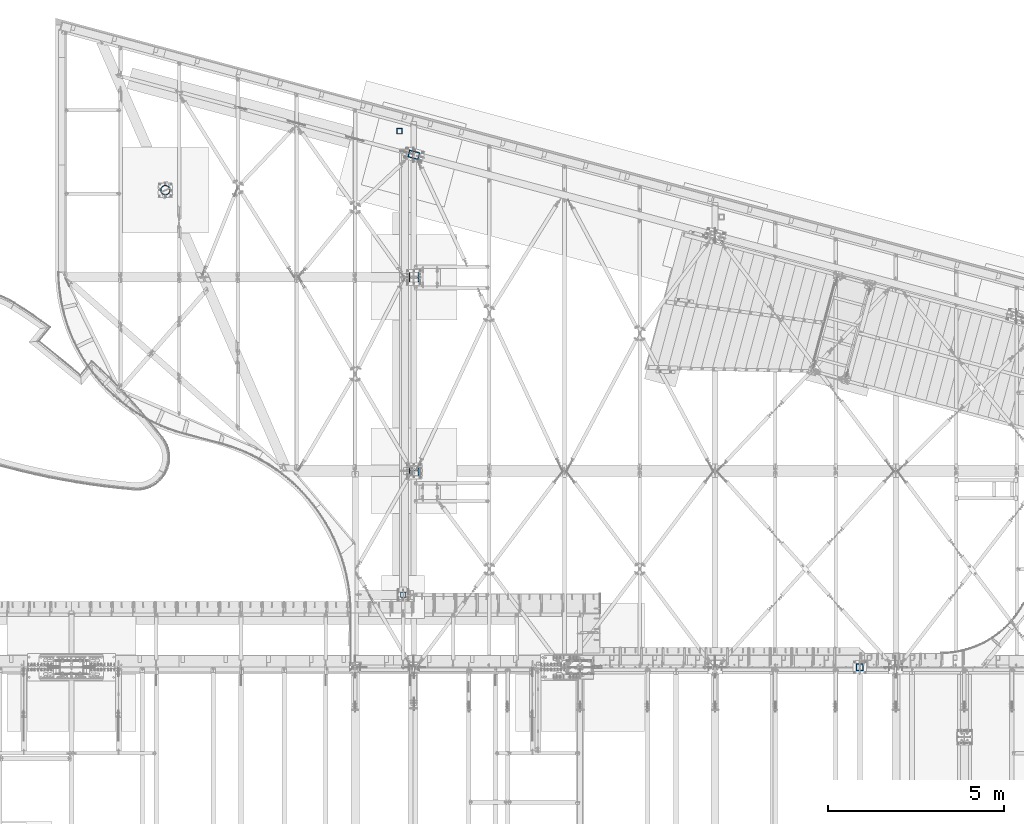
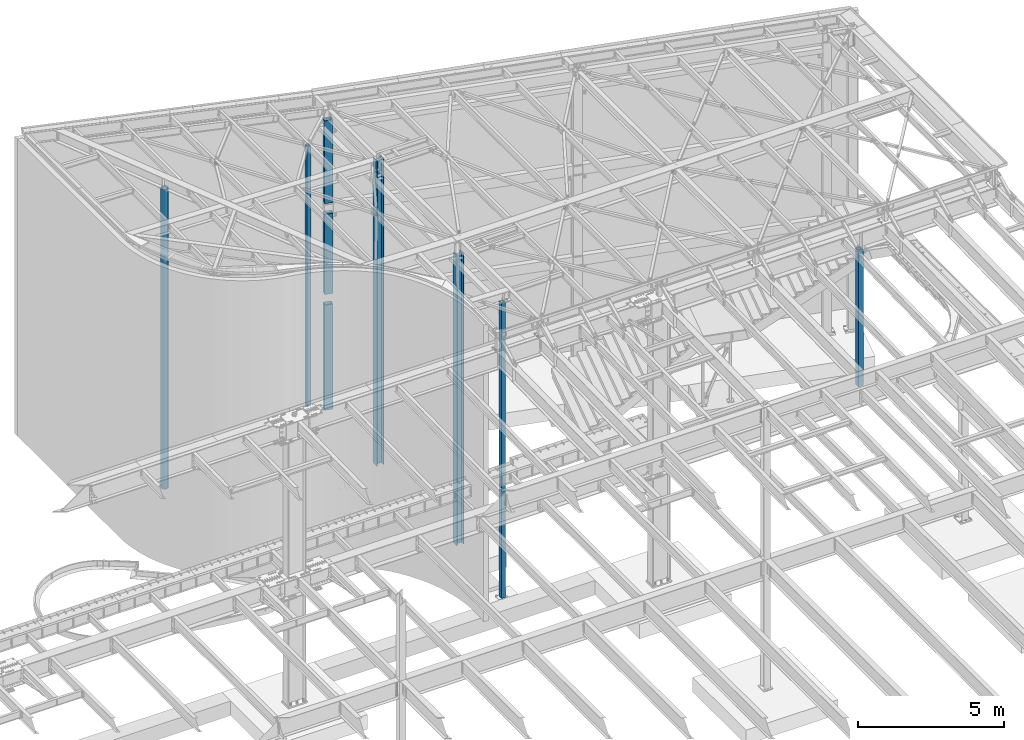
# One storey, part 914 of 1763: 9 columns, 7 elements without a shape of their own.
"""IFC2X3 building model written with IfcOpenShell, lengths in millimetres."""

from ifc_helpers import new_model, si_unit, frame, origin_with_axes, place, context, subcontext, project, spatial, faceted_brep, material, type_object, element, aggregate, save


model = new_model("IFC2X3")

# Units and contexts
model_context = context("Model", 3, precision=1e-05, world=origin_with_axes())
body_context = subcontext(model_context, "Body", "Model", "MODEL_VIEW")
ifc_project = project(units=[si_unit("LENGTHUNIT", "METRE", prefix="MILLI"), si_unit("AREAUNIT", "SQUARE_METRE"), si_unit("VOLUMEUNIT", "CUBIC_METRE"), si_unit("MASSUNIT", "GRAM", prefix="KILO"), si_unit("TIMEUNIT", "SECOND"), si_unit("PLANEANGLEUNIT", "RADIAN"), si_unit("SOLIDANGLEUNIT", "STERADIAN"), si_unit("THERMODYNAMICTEMPERATUREUNIT", "DEGREE_CELSIUS"), si_unit("LUMINOUSINTENSITYUNIT", "LUMEN")], contexts=[model_context])

# Site, building, storey
site_placement = place(None, origin_with_axes())
site = spatial("IfcSite", under=ifc_project, at=site_placement, CompositionType="ELEMENT")
building_placement = place(site_placement, origin_with_axes())
building = spatial("IfcBuilding", under=site, at=building_placement, Name="Undefined", CompositionType="ELEMENT")
storey_placement = place(building_placement, origin_with_axes())
storey = spatial("IfcBuildingStorey", under=building, at=storey_placement, Name="Undefined", CompositionType="ELEMENT", Elevation=0.0)

# Assembly, columns
assembly_1_placement = place(storey_placement, origin_with_axes())
assembly_1 = element("IfcElementAssembly", 1, at=assembly_1_placement, inside=storey, Name="COLUMN", AssemblyPlace="NOTDEFINED", PredefinedType="RIGID_FRAME")
ifc_material_1 = material()
column_type_1 = type_object("IfcColumnType", Name="HSS12X8X5/8", PredefinedType="NOTDEFINED")
column_1_placement = place(assembly_1_placement, frame((-39672.2896174351, 66681.4025701154, 8483.6), z_axis=(-0.965913267114846, 0.258865912030774, 0.0), x_axis=(0.0, 0.0, 1.0)))
column_1 = element("IfcColumn", 2, at=column_1_placement, type_object=column_type_1, material=ifc_material_1, Name="COLUMN", ObjectType="HSS12X8X5/8", context=body_context, shape_type="Brep", body=[
    faceted_brep([(3505.2, 85.725000000275, 136.525000000154), (3505.2, 85.7249999985142, -136.525000000358), (3489.32500001276, 101.599999998311, -152.400000000394), (3489.32499994588, 101.60000000026, 152.400000000154), (3505.2, -85.7250000002605, -136.52500000014), (3489.32500001817, -101.600000000253, -152.40000000014), (3505.1999999888, -85.7250000086715, 136.524999979003), (3489.32499994455, -101.599999998238, 152.400000000431), (22.2250001691827, -101.599999999904, -152.40000000006), (6.35000000000036, -85.7249999999112, -136.525000000045), (6.35000000000036, 85.7250000000859, -136.524999999936), (22.22500016919, 101.600000000093, -152.399999999921), (22.2249997738745, -101.599999773942, 152.400000112088), (6.35000000000036, -85.7250000000786, 136.524999999943), (22.2249996600258, 101.599999999904, 152.40000000006), (6.35000000000036, 85.7249999999112, 136.525000000045)], [[[0, 1, 2, 3]], [[4, 5, 2, 1]], [[6, 7, 5, 4]], [[8, 9, 10, 11]], [[12, 13, 9, 8]], [[14, 15, 13, 12]], [[13, 15, 0, 6]], [[9, 13, 6, 4]], [[10, 9, 4, 1]], [[15, 10, 1, 0]], [[14, 11, 10, 15]], [[11, 14, 3, 2]], [[8, 11, 2, 5]], [[12, 8, 5, 7]], [[14, 12, 7, 3]], [[0, 3, 7, 6]]]),
])
column_2_placement = place(assembly_1_placement, frame((-39672.2896174482, 66681.4025701186, 4673.6), z_axis=(-0.965913267114846, 0.258865912030774, 0.0), x_axis=(0.0, 0.0, 1.0)))
column_2 = element("IfcColumn", 3, at=column_2_placement, type_object=column_type_1, material=ifc_material_1, Name="COLUMN", ObjectType="HSS12X8X5/8", context=body_context, shape_type="Brep", body=[
    faceted_brep([(3397.25, 85.7249999999185, 136.525000000045), (3397.25, 85.7250000000859, -136.524999999936), (3381.37499999995, 101.600000000093, -152.399999999921), (3381.37500000165, 101.599999999904, 152.40000000006), (3397.25, -85.724999999904, -136.525000000045), (3381.37499999999, -101.599999999897, -152.40000000006), (3397.25, -85.7250000001004, 136.524999999914), (3381.37500000178, -101.600000000079, 152.399999999929), (22.2250001691827, -101.599999999904, -152.40000000006), (6.35000000000036, -85.7249999999112, -136.525000000045), (6.35000000000036, 85.7250000000859, -136.524999999936), (22.22500016919, 101.600000000093, -152.399999999921), (22.2249997738745, -101.599999773942, 152.400000112088), (6.35000000000036, -85.7250000000786, 136.524999999943), (22.2249996600258, 101.599999999904, 152.40000000006), (6.35000000000036, 85.7249999999112, 136.525000000045)], [[[0, 1, 2, 3]], [[4, 5, 2, 1]], [[6, 7, 5, 4]], [[8, 9, 10, 11]], [[12, 13, 9, 8]], [[14, 15, 13, 12]], [[13, 15, 0, 6]], [[9, 13, 6, 4]], [[10, 9, 4, 1]], [[15, 10, 1, 0]], [[14, 11, 10, 15]], [[11, 14, 3, 2]], [[8, 11, 2, 5]], [[12, 8, 5, 7]], [[14, 12, 7, 3]], [[0, 3, 7, 6]]]),
])
column_3_placement = place(assembly_1_placement, frame((-39672.2896174145, 66681.4025701092, -304.799999999999), z_axis=(-0.965913267114846, 0.258865912030774, 0.0), x_axis=(0.0, 0.0, 1.0)))
column_3 = element("IfcColumn", 4, at=column_3_placement, type_object=column_type_1, material=ifc_material_1, Name="COLUMN", ObjectType="HSS12X8X5/8", context=body_context, shape_type="Brep", body=[
    faceted_brep([(146.049999998875, 101.599999999904, 152.40000000006), (146.050000000008, 101.6000000001, -152.399999999921), (133.349999999999, 88.9000000001033, -139.69999999991), (133.349999999999, 88.9000000002707, 139.700000000703), (146.050000000045, -101.599999999897, -152.40000000006), (133.349999999999, -88.8999999998487, -139.700000000019), (146.04999999961, -101.599999999642, 152.399999999507), (133.349999999999, -88.9000000004235, 139.700000000703), (133.349999999999, 85.7249999999185, 136.525000000045), (133.349999999999, 85.7250000000931, -136.524999999936), (4565.65, 85.7250000000786, -136.524999999936), (4565.65, 85.7249999999112, 136.525000000045), (133.349999999999, -85.7250000000786, 136.524999999936), (4565.65000001169, -85.724999988437, 136.525000023285), (133.349999999999, -85.724999999904, -136.525000000045), (4565.65, -85.7249999999112, -136.525000000045), (4549.77500003684, -101.600000000093, 152.399999999921), (4549.77499998247, -101.599999999897, -152.40000000006), (4549.77500003671, 101.599999999904, 152.400000000052), (4549.7749999824, 101.600000000093, -152.399999999929)], [[[0, 1, 2, 3]], [[4, 5, 2, 1]], [[6, 7, 5, 4]], [[8, 9, 10, 11]], [[12, 8, 11, 13]], [[14, 12, 13, 15]], [[13, 16, 17, 15]], [[11, 18, 16, 13]], [[16, 18, 0, 6]], [[17, 16, 6, 4]], [[19, 17, 4, 1]], [[18, 19, 1, 0]], [[11, 10, 19, 18]], [[15, 17, 19, 10]], [[9, 14, 15, 10]], [[3, 2, 5, 7], [8, 12, 14, 9]], [[0, 3, 7, 6]]]),
])
aggregate(assembly_1, [column_1, column_2, column_3])

# Assembly, column
assembly_2_placement = place(storey_placement, origin_with_axes())
assembly_2 = element("IfcElementAssembly", 5, at=assembly_2_placement, inside=storey, Name="COLUMN", AssemblyPlace="NOTDEFINED", PredefinedType="RIGID_FRAME")
column_type_2 = type_object("IfcColumnType", Name="HSS6X6X5/8", PredefinedType="NOTDEFINED")
column_4_placement = place(assembly_2_placement, frame((-39977.0896174484, 54178.2, -457.2), z_axis=(0.0, 1.0, 0.0), x_axis=(0.0, 0.0, 1.0)))
column_4 = element("IfcColumn", 6, at=column_4_placement, type_object=column_type_2, material=ifc_material_1, Name="COLUMN", ObjectType="HSS6X6X5/8", context=body_context, shape_type="Brep", body=[
    faceted_brep([(63.4999999999973, 60.3249999999971, -60.3250000000007), (63.4999999999973, -60.3249999999971, -60.3250000000007), (12476.0619942482, -60.3249999999971, -60.3249999999971), (12472.3549225573, 60.3249999999971, -60.3249999999971), (63.4999999999973, -60.3249999999971, 60.3250000000007), (12476.0619942482, -60.3249999999971, 60.3249999999971), (63.4999999999973, 60.3249999999971, 60.3250000000007), (12472.3549225573, 60.3249999999971, 60.3249999999971), (63.4999999999973, 76.1999999999971, -76.2000000000007), (63.4999999999973, 76.1999999999971, 76.2000000000007), (12471.8671499664, 76.1999999999971, 76.1999999999971), (12471.8671499664, 76.1999999999971, -76.1999999999971), (63.4999999999973, -76.1999999999971, 76.2000000000007), (12476.5497668391, -76.1999999999971, 76.1999999999971), (63.4999999999973, -76.1999999999971, -76.2000000000007), (12476.5497668391, -76.1999999999971, -76.1999999999971)], [[[0, 1, 2, 3]], [[1, 4, 5, 2]], [[4, 6, 7, 5]], [[6, 0, 3, 7]], [[8, 9, 10, 11]], [[9, 12, 13, 10]], [[12, 14, 15, 13]], [[14, 8, 11, 15]], [[13, 15, 11, 10], [5, 7, 3, 2]], [[14, 12, 9, 8], [6, 4, 1, 0]]]),
])
aggregate(assembly_2, [column_4])

assembly_3_placement = place(storey_placement, origin_with_axes())
assembly_3 = element("IfcElementAssembly", 7, at=assembly_3_placement, inside=storey, Name="COLUMN", AssemblyPlace="NOTDEFINED", PredefinedType="RIGID_FRAME")
column_type_3 = type_object("IfcColumnType", Name="HSS6X6X3/8", PredefinedType="NOTDEFINED")
column_5_placement = place(assembly_3_placement, frame((-40078.6896174484, 67354.45, -304.8), z_axis=(-1.0, 0.0, 0.0), x_axis=(0.0, 0.0, 1.0)))
column_5 = element("IfcColumn", 8, at=column_5_placement, type_object=column_type_3, material=ifc_material_1, Name="COLUMN", ObjectType="HSS6X6X3/8", context=body_context, shape_type="Brep", body=[
    faceted_brep([(0.0, 66.6749999999993, -66.6749999999993), (0.0, -66.6750000000029, -66.6749999999993), (10934.7, -66.6750000000029, -66.6749999999993), (10934.7, 66.6750000000029, -66.6749999999993), (0.0, -66.6750000000029, 66.6749999999993), (10934.7, -66.6750000000029, 66.6749999999993), (0.0, 66.6750000000029, 66.6749999999993), (10934.7, 66.6750000000029, 66.6749999999993), (9.09494701772928e-13, 76.2000000000007, -76.2000000000844), (0.0, 76.2000000000007, 76.2000000000771), (10934.7, 76.1999999999971, 76.2000000000007), (10934.7, 76.1999999999971, -76.2000000000007), (0.0, -76.1999999999971, 76.1999999999971), (10934.7, -76.1999999999971, 76.2000000000007), (9.09494701772928e-13, -76.2000000000007, -76.2000000000844), (10934.7, -76.1999999999971, -76.2000000000007)], [[[0, 1, 2, 3]], [[1, 4, 5, 2]], [[4, 6, 7, 5]], [[6, 0, 3, 7]], [[8, 9, 10, 11]], [[9, 12, 13, 10]], [[12, 14, 15, 13]], [[14, 8, 11, 15]], [[13, 15, 11, 10], [5, 7, 3, 2]], [[14, 12, 9, 8], [6, 4, 1, 0]]]),
])
aggregate(assembly_3, [column_5])

assembly_4_placement = place(storey_placement, origin_with_axes())
assembly_4 = element("IfcElementAssembly", 9, at=assembly_4_placement, inside=storey, Name="COLUMN", AssemblyPlace="NOTDEFINED", PredefinedType="RIGID_FRAME")
ifc_material_2 = material()
column_type_4 = type_object("IfcColumnType", Name="PIPE10XS", PredefinedType="NOTDEFINED")
column_6_placement = place(assembly_4_placement, frame((-46733.4896174484, 65678.05, -457.200000000008), z_axis=(-1.0, 0.0, 0.0), x_axis=(0.0, 0.0, 1.0)))
column_6 = element("IfcColumn", 10, at=column_6_placement, type_object=column_type_4, material=ifc_material_2, Name="COLUMN", ObjectType="PIPE10XS", context=body_context, shape_type="Brep", body=[
    faceted_brep([(69.8500000000116, -123.824999999997, 0.0), (69.8500000000116, -120.720448725915, 27.5536546471412), (12629.8246584979, -120.720448725915, 27.5536546471412), (12629.653623038, -123.824999999997, 0.0), (69.8500000000116, -111.56247006802, 53.7256539962327), (12630.0578157663, -111.56247006802, 53.7256539962327), (69.8500000000116, -96.8102833166049, 77.2036247151555), (12630.3414033639, -96.8102833166049, 77.2036247151555), (69.8500000000116, -77.2036247151555, 96.8102833166049), (12630.6612010247, -77.2036247151555, 96.8102833166049), (69.8500000000116, -53.7256539962254, 111.56247006802), (12631.0011727584, -53.7256539962254, 111.56247006802), (69.8500000000116, -27.5536546471412, 120.720448725915), (12631.3442709629, -27.5536546471412, 120.720448725915), (69.8500000000116, 0.0, 123.824999999997), (12631.6732912613, 0.0, 123.824999999997), (69.8500000000116, 27.5536546471412, 120.720448725915), (12631.9717352022, 27.5536546471412, 120.720448725915), (69.8500000000116, 53.7256539962254, 111.56247006802), (12632.2246375601, 53.7256539962254, 111.56247006802), (69.8500000000116, 77.2036247151555, 96.8102833166049), (12632.4193167547, 77.2036247151555, 96.8102833166049), (69.8500000000116, 96.8102833166049, 77.2036247151555), (12632.5460107584, 96.8102833166049, 77.2036247151555), (69.8500000000116, 111.56247006802, 53.7256539962327), (12632.5983666048, 111.56247006802, 53.7256539962327), (69.8500000000116, 120.720448725915, 27.5536546471412), (12632.573758953, 120.720448725915, 27.5536546471412), (69.8500000000116, 123.824999999997, 0.0), (12632.4734217336, 123.824999999997, 0.0), (69.8500000000116, 120.720448725915, -27.5536546471412), (12632.3023862737, 120.720448725915, -27.5536546471412), (69.8500000000116, 111.56247006802, -53.7256539962327), (12632.0692290054, 111.56247006802, -53.7256539962327), (69.8500000000116, 96.8102833166049, -77.2036247151555), (12631.7856414077, 96.8102833166049, -77.2036247151555), (69.8500000000116, 77.2036247151555, -96.8102833166049), (12631.4658437469, 77.2036247151555, -96.8102833166049), (69.8500000000116, 53.7256539962254, -111.56247006802), (12631.1258720132, 53.7256539962254, -111.56247006802), (69.8500000000116, 27.5536546471412, -120.720448725915), (12630.7827738088, 27.5536546471412, -120.720448725915), (69.8500000000116, 0.0, -123.824999999997), (12630.4537535103, 0.0, -123.824999999997), (69.8500000000116, -27.5536546471412, -120.720448725915), (12630.1553095694, -27.5536546471412, -120.720448725915), (69.8500000000116, -53.7256539962254, -111.56247006802), (12629.9024072116, -53.7256539962254, -111.56247006802), (69.8500000000116, -77.2036247151555, -96.8102833166049), (12629.7077280169, -77.2036247151555, -96.8102833166049), (69.8500000000116, -96.8102833166049, -77.2036247151555), (12629.5810340132, -96.8102833166049, -77.2036247151555), (69.8500000000116, -111.56247006802, -53.7256539962327), (12629.5286781669, -111.56247006802, -53.7256539962327), (69.8500000000116, -120.720448725915, -27.5536546471412), (12629.5532858186, -120.720448725915, -27.5536546471412), (69.8500000000116, -136.524999999994, 0.0), (69.8500000000116, -133.102033210627, -30.3796705083878), (12629.3983897604, -133.102033210627, -30.3796705083878), (12629.5090179767, -136.524999999994, 0.0), (69.8500000000116, -123.004774690373, -59.2359774830256), (12629.371258247, -123.004774690373, -59.2359774830256), (69.8500000000116, -106.739543143951, -85.1219451987636), (12629.4289839237, -106.739543143951, -85.1219451987636), (69.8500000000116, -85.1219451987708, -106.739543143951), (12629.5686721842, -85.1219451987708, -106.739543143951), (69.8500000000116, -59.2359774830256, -123.00477469038), (12629.7833184757, -59.2359774830256, -123.00477469038), (69.8500000000116, -30.3796705083805, -133.10203321062), (12630.062159537, -30.3796705083805, -133.10203321062), (69.8500000000116, 0.0, -136.525000000001), (12630.3912131128, 0.0, -136.525000000001), (69.8500000000116, 30.3796705083805, -133.10203321062), (12630.7539790829, 30.3796705083805, -133.10203321062), (69.8500000000116, 59.2359774830256, -123.00477469038), (12631.1322668468, 59.2359774830256, -123.00477469038), (69.8500000000116, 85.1219451987708, -106.739543143951), (12631.5071074763, 85.1219451987708, -106.739543143951), (69.8500000000116, 106.739543143951, -85.1219451987636), (12631.8597048971, 106.739543143951, -85.1219451987636), (69.8500000000116, 123.004774690373, -59.2359774830256), (12632.1723784022, 123.004774690373, -59.2359774830256), (69.8500000000116, 133.102033210627, -30.3796705083878), (12632.4294492365, 133.102033210627, -30.3796705083878), (69.8500000000116, 136.524999999994, 0.0), (12632.6180267949, 136.524999999994, 0.0), (69.8500000000116, 133.102033210627, 30.3796705083878), (12632.7286550112, 133.102033210627, 30.3796705083878), (69.8500000000116, 123.004774690373, 59.2359774830256), (12632.7557865247, 123.004774690373, 59.2359774830256), (69.8500000000116, 106.739543143951, 85.1219451987636), (12632.6980608479, 106.739543143951, 85.1219451987636), (69.8500000000116, 85.1219451987708, 106.739543143951), (12632.5583725874, 85.1219451987708, 106.739543143951), (69.8500000000116, 59.2359774830256, 123.00477469038), (12632.3437262959, 59.2359774830256, 123.00477469038), (69.8500000000116, 30.3796705083805, 133.10203321062), (12632.0648852346, 30.3796705083805, 133.10203321062), (69.8500000000116, 0.0, 136.525000000001), (12631.7358316588, 0.0, 136.525000000001), (69.8500000000116, -30.3796705083805, 133.10203321062), (12631.3730656887, -30.3796705083805, 133.10203321062), (69.8500000000116, -59.2359774830256, 123.00477469038), (12630.9947779249, -59.2359774830256, 123.00477469038), (69.8500000000116, -85.1219451987708, 106.739543143951), (12630.6199372953, -85.1219451987708, 106.739543143951), (69.8500000000116, -106.739543143951, 85.1219451987636), (12630.2673398745, -106.739543143951, 85.1219451987636), (69.8500000000116, -123.004774690373, 59.2359774830256), (12629.9546663694, -123.004774690373, 59.2359774830256), (69.8500000000116, -133.102033210627, 30.3796705083878), (12629.6975955351, -133.102033210627, 30.3796705083878)], [[[0, 1, 2, 3]], [[1, 4, 5, 2]], [[4, 6, 7, 5]], [[6, 8, 9, 7]], [[8, 10, 11, 9]], [[10, 12, 13, 11]], [[12, 14, 15, 13]], [[14, 16, 17, 15]], [[16, 18, 19, 17]], [[18, 20, 21, 19]], [[20, 22, 23, 21]], [[22, 24, 25, 23]], [[24, 26, 27, 25]], [[26, 28, 29, 27]], [[28, 30, 31, 29]], [[30, 32, 33, 31]], [[32, 34, 35, 33]], [[34, 36, 37, 35]], [[36, 38, 39, 37]], [[38, 40, 41, 39]], [[40, 42, 43, 41]], [[42, 44, 45, 43]], [[44, 46, 47, 45]], [[46, 48, 49, 47]], [[48, 50, 51, 49]], [[50, 52, 53, 51]], [[52, 54, 55, 53]], [[54, 0, 3, 55]], [[56, 57, 58, 59]], [[57, 60, 61, 58]], [[60, 62, 63, 61]], [[62, 64, 65, 63]], [[64, 66, 67, 65]], [[66, 68, 69, 67]], [[68, 70, 71, 69]], [[70, 72, 73, 71]], [[72, 74, 75, 73]], [[74, 76, 77, 75]], [[76, 78, 79, 77]], [[78, 80, 81, 79]], [[80, 82, 83, 81]], [[82, 84, 85, 83]], [[84, 86, 87, 85]], [[86, 88, 89, 87]], [[88, 90, 91, 89]], [[90, 92, 93, 91]], [[92, 94, 95, 93]], [[94, 96, 97, 95]], [[96, 98, 99, 97]], [[98, 100, 101, 99]], [[100, 102, 103, 101]], [[102, 104, 105, 103]], [[104, 106, 107, 105]], [[106, 108, 109, 107]], [[108, 110, 111, 109]], [[110, 56, 59, 111]], [[61, 63, 65, 67, 69, 71, 73, 75, 77, 79, 81, 83, 85, 87, 89, 91, 93, 95, 97, 99, 101, 103, 105, 107, 109, 111, 59, 58], [5, 7, 9, 11, 13, 15, 17, 19, 21, 23, 25, 27, 29, 31, 33, 35, 37, 39, 41, 43, 45, 47, 49, 51, 53, 55, 3, 2]], [[110, 108, 106, 104, 102, 100, 98, 96, 94, 92, 90, 88, 86, 84, 82, 80, 78, 76, 74, 72, 70, 68, 66, 64, 62, 60, 57, 56], [54, 52, 50, 48, 46, 44, 42, 40, 38, 36, 34, 32, 30, 28, 26, 24, 22, 20, 18, 16, 14, 12, 10, 8, 6, 4, 1, 0]]]),
])
aggregate(assembly_4, [column_6])

assembly_5_placement = place(storey_placement, origin_with_axes())
assembly_5 = element("IfcElementAssembly", 11, at=assembly_5_placement, inside=storey, Name="COLUMN", AssemblyPlace="NOTDEFINED", PredefinedType="RIGID_FRAME")
ifc_material_3 = material(Name="STEEL/A992")
column_type_5 = type_object("IfcColumnType", Name="W10X100", PredefinedType="NOTDEFINED")
column_7_placement = place(assembly_5_placement, frame((-39672.2896174484, 57702.45, -457.200000000008), z_axis=(-1.0, 0.0, 0.0), x_axis=(0.0, 0.0, 1.0)))
column_7 = element("IfcColumn", 12, at=column_7_placement, type_object=column_type_5, material=ifc_material_3, Name="COLUMN", ObjectType="W10X100", context=body_context, shape_type="Brep", body=[
    faceted_brep([(88.9000000000079, 131.762499999997, -141.287499999999), (88.9000000000079, 131.762499999997, -112.712500000001), (12261.85, 131.762499999997, -112.712500000001), (12261.85, 131.762499999997, -141.287499999999), (88.9000000000079, 8.73124999999709, -112.712500000001), (12261.85, 8.73124999999709, -112.712500000001), (88.9000000000079, 8.73124999999709, 112.712500000001), (12261.85, 8.73124999999709, 112.712500000001), (88.9000000000079, 131.762499999997, 112.712500000001), (12261.85, 131.762499999997, 112.712500000001), (88.9000000000079, 131.762499999997, 141.287499999999), (12261.85, 131.762499999997, 141.287499999999), (88.9000000000079, -131.762499999997, 141.287499999999), (12261.85, -131.762499999997, 141.287499999999), (88.9000000000079, -131.762499999997, 112.712500000001), (12261.85, -131.762499999997, 112.712500000001), (88.9000000000079, -8.73124999999709, 112.712500000001), (12261.85, -8.73124999999709, 112.712500000001), (88.9000000000079, -8.73124999999709, -112.712500000001), (12261.85, -8.73124999999709, -112.712500000001), (88.9000000000079, -131.762499999997, -112.712500000001), (12261.85, -131.762499999997, -112.712500000001), (88.9000000000079, -131.762499999997, -141.287499999999), (12261.85, -131.762499999997, -141.287499999999)], [[[0, 1, 2, 3]], [[1, 4, 5, 2]], [[4, 6, 7, 5]], [[6, 8, 9, 7]], [[8, 10, 11, 9]], [[10, 12, 13, 11]], [[12, 14, 15, 13]], [[14, 16, 17, 15]], [[16, 18, 19, 17]], [[18, 20, 21, 19]], [[20, 22, 23, 21]], [[22, 0, 3, 23]], [[5, 7, 9, 11, 13, 15, 17, 19, 21, 23, 3, 2]], [[22, 20, 18, 16, 14, 12, 10, 8, 6, 4, 1, 0]]]),
])
aggregate(assembly_5, [column_7])

assembly_6_placement = place(storey_placement, origin_with_axes())
assembly_6 = element("IfcElementAssembly", 13, at=assembly_6_placement, inside=storey, Name="COLUMN", AssemblyPlace="NOTDEFINED", PredefinedType="RIGID_FRAME")
column_8_placement = place(assembly_6_placement, frame((-39672.2896174484, 63201.55, -457.200000000008), z_axis=(-1.0, 0.0, 0.0), x_axis=(0.0, 0.0, 1.0)))
column_8 = element("IfcColumn", 14, at=column_8_placement, type_object=column_type_5, material=ifc_material_3, Name="COLUMN", ObjectType="W10X100", context=body_context, shape_type="Brep", body=[
    faceted_brep([(88.9000000000079, 131.762499999997, -141.287499999999), (88.9000000000079, 131.762499999997, -112.712500000001), (12890.5, 131.762499999997, -112.712500000001), (12890.5, 131.762499999997, -141.287499999999), (88.9000000000079, 8.73124999999709, -112.712500000001), (12890.5, 8.73124999999709, -112.712500000001), (88.9000000000079, 8.73124999999709, 112.712500000001), (12890.5, 8.73124999999709, 112.712500000001), (88.9000000000079, 131.762499999997, 112.712500000001), (12890.5, 131.762499999997, 112.712500000001), (88.9000000000079, 131.762499999997, 141.287499999999), (12890.5, 131.762499999997, 141.287499999999), (88.9000000000079, -131.762499999997, 141.287499999999), (12890.5, -131.762499999997, 141.287499999999), (88.9000000000079, -131.762499999997, 112.712500000001), (12890.5, -131.762499999997, 112.712500000001), (88.9000000000079, -8.73124999999709, 112.712500000001), (12890.5, -8.73124999999709, 112.712500000001), (88.9000000000079, -8.73124999999709, -112.712500000001), (12890.5, -8.73124999999709, -112.712500000001), (88.9000000000079, -131.762499999997, -112.712500000001), (12890.5, -131.762499999997, -112.712500000001), (88.9000000000079, -131.762499999997, -141.287499999999), (12890.5, -131.762499999997, -141.287499999999)], [[[0, 1, 2, 3]], [[1, 4, 5, 2]], [[4, 6, 7, 5]], [[6, 8, 9, 7]], [[8, 10, 11, 9]], [[10, 12, 13, 11]], [[12, 14, 15, 13]], [[14, 16, 17, 15]], [[16, 18, 19, 17]], [[18, 20, 21, 19]], [[20, 22, 23, 21]], [[22, 0, 3, 23]], [[5, 7, 9, 11, 13, 15, 17, 19, 21, 23, 3, 2]], [[22, 20, 18, 16, 14, 12, 10, 8, 6, 4, 1, 0]]]),
])
aggregate(assembly_6, [column_8])

assembly_7_placement = place(storey_placement, origin_with_axes())
assembly_7 = element("IfcElementAssembly", 15, at=assembly_7_placement, inside=storey, Name="COLUMN", AssemblyPlace="NOTDEFINED", PredefinedType="RIGID_FRAME")
column_type_6 = type_object("IfcColumnType", Name="HSS8X8X1/2", PredefinedType="NOTDEFINED")
column_9_placement = place(assembly_7_placement, frame((-26999.6372736983, 52120.8, 5194.3), z_axis=(0.0, 1.0, 0.0), x_axis=(0.0, 0.0, 1.0)))
column_9 = element("IfcColumn", 16, at=column_9_placement, type_object=column_type_6, material=ifc_material_1, Name="COLUMN", ObjectType="HSS8X8X1/2", context=body_context, shape_type="Brep", body=[
    faceted_brep([(19.0499999999993, 88.9000000000015, -88.9000000000015), (19.0499999999993, -88.9000000000015, -88.9000000000015), (5740.39999176536, -88.9000000000015, -88.9000000000015), (5740.39999176536, 88.9000000000015, -88.9000000000015), (19.0499999999993, -88.9000000000015, 88.9000000000015), (5740.39999176536, -88.9000000000015, 88.9000000000015), (19.0499999999993, 88.9000000000015, 88.9000000000015), (5740.39999176536, 88.9000000000015, 88.9000000000015), (19.0499917653633, 101.599999999999, -101.599999999999), (19.0499917653633, 101.599999999999, 101.599999999999), (5740.39999176536, 101.599999999999, 101.599999999999), (5740.39999176536, 101.599999999999, -101.599999999999), (19.0499917653633, -101.599999999999, 101.599999999999), (5740.39999176536, -101.599999999999, 101.599999999999), (19.0499917653633, -101.599999999999, -101.599999999999), (5740.39999176536, -101.599999999999, -101.599999999999)], [[[0, 1, 2, 3]], [[1, 4, 5, 2]], [[4, 6, 7, 5]], [[6, 0, 3, 7]], [[8, 9, 10, 11]], [[9, 12, 13, 10]], [[12, 14, 15, 13]], [[14, 8, 11, 15]], [[13, 15, 11, 10], [5, 7, 3, 2]], [[14, 12, 9, 8], [6, 4, 1, 0]]]),
])
aggregate(assembly_7, [column_9])

save(model, "model.ifc")
